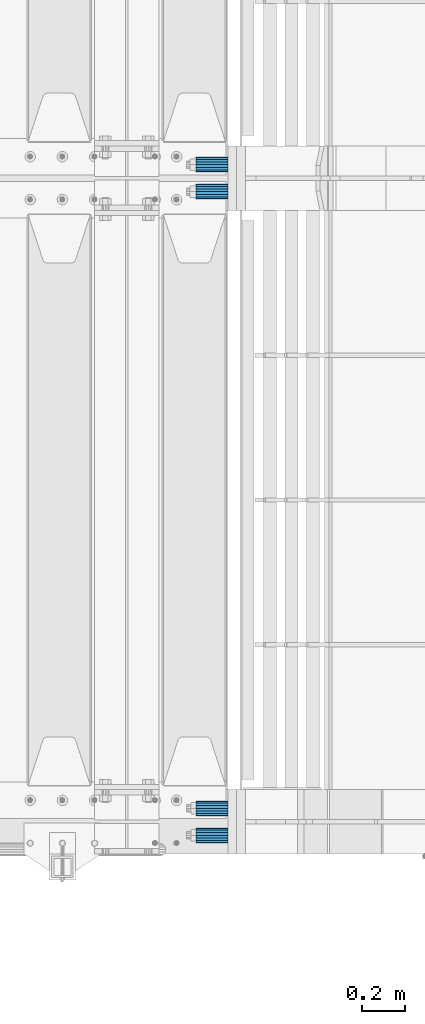
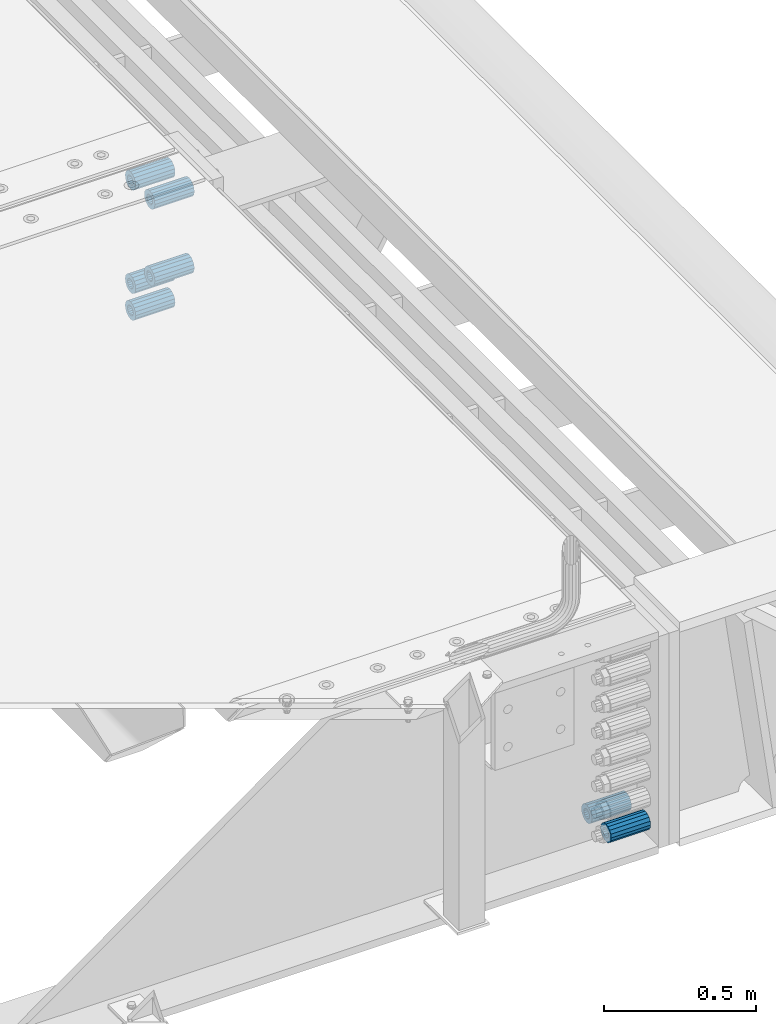
# One storey, part 162 of 257: 7 beams.
"""IFC2X3 building model written with IfcOpenShell, lengths in millimetres."""

from ifc_helpers import new_model, si_unit, frame, origin_with_axes, place, context, subcontext, project, spatial, faceted_brep, material, type_object, element, save


model = new_model("IFC2X3")

# Units and contexts
model_context = context("Model", 3, precision=1e-05, world=origin_with_axes())
body_context = subcontext(model_context, "Body", "Model", "MODEL_VIEW")
ifc_project = project(units=[si_unit("LENGTHUNIT", "METRE", prefix="MILLI"), si_unit("AREAUNIT", "SQUARE_METRE"), si_unit("VOLUMEUNIT", "CUBIC_METRE"), si_unit("MASSUNIT", "GRAM", prefix="KILO"), si_unit("TIMEUNIT", "SECOND"), si_unit("PLANEANGLEUNIT", "RADIAN"), si_unit("SOLIDANGLEUNIT", "STERADIAN"), si_unit("THERMODYNAMICTEMPERATUREUNIT", "DEGREE_CELSIUS"), si_unit("LUMINOUSINTENSITYUNIT", "LUMEN")], contexts=[model_context])

# Site, building, storey
site_placement = place(None, origin_with_axes())
site = spatial("IfcSite", under=ifc_project, at=site_placement, CompositionType="ELEMENT")
building_placement = place(site_placement, origin_with_axes())
building = spatial("IfcBuilding", under=site, at=building_placement, Name="Standard", CompositionType="ELEMENT")
storey_placement = place(building_placement, origin_with_axes())
storey = spatial("IfcBuildingStorey", under=building, at=storey_placement, Name="Undefined", CompositionType="ELEMENT", Elevation=0.0)

# Beams
ifc_material = material()
beam_type = type_object("IfcBeamType", PredefinedType="NOTDEFINED")
beam_1_placement = place(storey_placement, frame((59117.0, 3063.0, -84.0000000000001), z_axis=(0.0, 0.0, 1.0), x_axis=(1.0, 0.0, 0.0)))
element("IfcBeam", 1, at=beam_1_placement, inside=storey, type_object=beam_type, material=ifc_material, context=body_context, shape_type="Brep", body=[
    faceted_brep([(-1.3120632047503e-07, -18.9999999995493, -6.27187546342611e-09), (0.0, -17.5537111177146, 7.27098521493672), (150.0, -17.5537111177146, 7.27098521493672), (150.0, -19.0, 0.0), (0.0, -13.4350288425449, 13.4350288425444), (150.0, -13.4350288425449, 13.4350288425444), (0.0, -7.27098521493645, 17.5537111177144), (150.0, -7.27098521493645, 17.5537111177144), (-6.33792751614237e-09, 4.50654624728486e-10, 18.9999999937208), (150.0, 0.0, 19.0), (0.0, 7.27098521493645, 17.5537111177144), (150.0, 7.27098521493645, 17.5537111177144), (0.0, 13.4350288425449, 13.4350288425444), (150.0, 13.4350288425449, 13.4350288425444), (0.0, 17.5537111177146, 7.2709852149367), (150.0, 17.5537111177146, 7.2709852149367), (1.33208345687308e-07, 19.0000000004507, -6.27187546342611e-09), (150.0, 19.0, 0.0), (0.0, 17.5537111177146, -7.2709852149367), (150.0, 17.5537111177146, -7.2709852149367), (0.0, 13.4350288425449, -13.4350288425444), (150.0, 13.4350288425449, -13.4350288425444), (0.0, 7.27098521493645, -17.5537111177144), (150.0, 7.27098521493645, -17.5537111177144), (8.33983904158231e-09, 4.50654624728486e-10, -19.0000000062719), (150.0, 0.0, -19.0), (0.0, -7.27098521493645, -17.5537111177144), (150.0, -7.27098521493645, -17.5537111177144), (0.0, -13.4350288425449, -13.4350288425444), (150.0, -13.4350288425449, -13.4350288425444), (0.0, -17.5537111177146, -7.2709852149367), (150.0, -17.5537111177146, -7.2709852149367), (7.27595761418343e-12, -35.0, 0.0), (1.45519152283669e-11, -32.335783637895, -13.3939201327781), (150.0, -32.3357836378955, -13.3939201327782), (150.0, -35.0, 0.0), (7.27595761418343e-12, -24.7487373415292, -24.748737341529), (150.0, -24.7487373415288, -24.7487373415292), (7.27595761418343e-12, -13.3939201327781, -32.335783637895), (150.0, -13.3939201327785, -32.335783637895), (7.27595761418343e-12, 0.0, -35.0), (150.0, 0.0, -35.0), (7.27595761418343e-12, 13.3939201327782, -32.335783637895), (150.0, 13.3939201327785, -32.335783637895), (7.27595761418343e-12, 24.7487373415292, -24.748737341529), (150.0, 24.7487373415288, -24.7487373415292), (1.45519152283669e-11, 32.335783637895, -13.3939201327781), (150.0, 32.3357836378955, -13.3939201327781), (7.27595761418343e-12, 35.0, 0.0), (150.0, 35.0, 0.0), (7.27595761418343e-12, 32.335783637895, 13.3939201327782), (150.0, 32.3357836378955, 13.3939201327781), (7.27595761418343e-12, 24.7487373415292, 24.7487373415291), (150.0, 24.7487373415288, 24.7487373415292), (1.45519152283669e-11, 13.3939201327781, 32.335783637895), (150.0, 13.3939201327785, 32.335783637895), (1.45519152283669e-11, 0.0, 35.0000000000001), (150.0, 0.0, 35.0), (1.45519152283669e-11, -13.3939201327781, 32.335783637895), (150.0, -13.3939201327785, 32.335783637895), (7.27595761418343e-12, -24.7487373415292, 24.7487373415291), (150.0, -24.7487373415288, 24.7487373415292), (7.27595761418343e-12, -32.335783637895, 13.3939201327782), (150.0, -32.3357836378955, 13.3939201327781)], [[[0, 1, 2, 3]], [[1, 4, 5, 2]], [[4, 6, 7, 5]], [[6, 8, 9, 7]], [[8, 10, 11, 9]], [[10, 12, 13, 11]], [[12, 14, 15, 13]], [[14, 16, 17, 15]], [[16, 18, 19, 17]], [[18, 20, 21, 19]], [[20, 22, 23, 21]], [[22, 24, 25, 23]], [[24, 26, 27, 25]], [[26, 28, 29, 27]], [[28, 30, 31, 29]], [[30, 0, 3, 31]], [[32, 33, 34, 35]], [[33, 36, 37, 34]], [[36, 38, 39, 37]], [[38, 40, 41, 39]], [[40, 42, 43, 41]], [[42, 44, 45, 43]], [[44, 46, 47, 45]], [[46, 48, 49, 47]], [[48, 50, 51, 49]], [[50, 52, 53, 51]], [[52, 54, 55, 53]], [[54, 56, 57, 55]], [[56, 58, 59, 57]], [[58, 60, 61, 59]], [[60, 62, 63, 61]], [[62, 32, 35, 63]], [[37, 39, 41, 43, 45, 47, 49, 51, 53, 55, 57, 59, 61, 63, 35, 34], [5, 7, 9, 11, 13, 15, 17, 19, 21, 23, 25, 27, 29, 31, 3, 2]], [[62, 60, 58, 56, 54, 52, 50, 48, 46, 44, 42, 40, 38, 36, 33, 32], [30, 28, 26, 24, 22, 20, 18, 16, 14, 12, 10, 8, 6, 4, 1, 0]]]),
])
beam_2_placement = place(storey_placement, frame((59117.0, 2937.0, -84.0000000000001), z_axis=(0.0, 0.0, 1.0), x_axis=(1.0, 0.0, 0.0)))
element("IfcBeam", 2, at=beam_2_placement, inside=storey, type_object=beam_type, material=ifc_material, context=body_context, shape_type="Brep", body=[
    faceted_brep([(-1.3120632047503e-07, -18.9999999995493, -6.27187546342611e-09), (0.0, -17.5537111177146, 7.27098521493672), (150.0, -17.5537111177146, 7.27098521493672), (150.0, -19.0, 0.0), (0.0, -13.4350288425449, 13.4350288425444), (150.0, -13.4350288425449, 13.4350288425444), (0.0, -7.27098521493645, 17.5537111177144), (150.0, -7.27098521493645, 17.5537111177144), (-6.33792751614237e-09, 4.50654624728486e-10, 18.9999999937208), (150.0, 0.0, 19.0), (0.0, 7.27098521493645, 17.5537111177144), (150.0, 7.27098521493645, 17.5537111177144), (0.0, 13.4350288425449, 13.4350288425444), (150.0, 13.4350288425449, 13.4350288425444), (0.0, 17.5537111177146, 7.2709852149367), (150.0, 17.5537111177146, 7.2709852149367), (1.33208345687308e-07, 19.0000000004507, -6.27187546342611e-09), (150.0, 19.0, 0.0), (0.0, 17.5537111177146, -7.2709852149367), (150.0, 17.5537111177146, -7.2709852149367), (0.0, 13.4350288425449, -13.4350288425444), (150.0, 13.4350288425449, -13.4350288425444), (0.0, 7.27098521493645, -17.5537111177144), (150.0, 7.27098521493645, -17.5537111177144), (8.33983904158231e-09, 4.50654624728486e-10, -19.0000000062719), (150.0, 0.0, -19.0), (0.0, -7.27098521493645, -17.5537111177144), (150.0, -7.27098521493645, -17.5537111177144), (0.0, -13.4350288425449, -13.4350288425444), (150.0, -13.4350288425449, -13.4350288425444), (0.0, -17.5537111177146, -7.2709852149367), (150.0, -17.5537111177146, -7.2709852149367), (7.27595761418343e-12, -35.0, 0.0), (1.45519152283669e-11, -32.335783637895, -13.3939201327781), (150.0, -32.3357836378955, -13.3939201327782), (150.0, -35.0, 0.0), (7.27595761418343e-12, -24.7487373415292, -24.748737341529), (150.0, -24.7487373415288, -24.7487373415292), (7.27595761418343e-12, -13.3939201327781, -32.335783637895), (150.0, -13.3939201327785, -32.335783637895), (7.27595761418343e-12, 0.0, -35.0), (150.0, 0.0, -35.0), (7.27595761418343e-12, 13.3939201327782, -32.335783637895), (150.0, 13.3939201327785, -32.335783637895), (7.27595761418343e-12, 24.7487373415292, -24.748737341529), (150.0, 24.7487373415288, -24.7487373415292), (1.45519152283669e-11, 32.335783637895, -13.3939201327781), (150.0, 32.3357836378955, -13.3939201327781), (7.27595761418343e-12, 35.0, 0.0), (150.0, 35.0, 0.0), (7.27595761418343e-12, 32.335783637895, 13.3939201327782), (150.0, 32.3357836378955, 13.3939201327781), (7.27595761418343e-12, 24.7487373415292, 24.7487373415291), (150.0, 24.7487373415288, 24.7487373415292), (1.45519152283669e-11, 13.3939201327781, 32.335783637895), (150.0, 13.3939201327785, 32.335783637895), (1.45519152283669e-11, 0.0, 35.0000000000001), (150.0, 0.0, 35.0), (1.45519152283669e-11, -13.3939201327781, 32.335783637895), (150.0, -13.3939201327785, 32.335783637895), (7.27595761418343e-12, -24.7487373415292, 24.7487373415291), (150.0, -24.7487373415288, 24.7487373415292), (7.27595761418343e-12, -32.335783637895, 13.3939201327782), (150.0, -32.3357836378955, 13.3939201327781)], [[[0, 1, 2, 3]], [[1, 4, 5, 2]], [[4, 6, 7, 5]], [[6, 8, 9, 7]], [[8, 10, 11, 9]], [[10, 12, 13, 11]], [[12, 14, 15, 13]], [[14, 16, 17, 15]], [[16, 18, 19, 17]], [[18, 20, 21, 19]], [[20, 22, 23, 21]], [[22, 24, 25, 23]], [[24, 26, 27, 25]], [[26, 28, 29, 27]], [[28, 30, 31, 29]], [[30, 0, 3, 31]], [[32, 33, 34, 35]], [[33, 36, 37, 34]], [[36, 38, 39, 37]], [[38, 40, 41, 39]], [[40, 42, 43, 41]], [[42, 44, 45, 43]], [[44, 46, 47, 45]], [[46, 48, 49, 47]], [[48, 50, 51, 49]], [[50, 52, 53, 51]], [[52, 54, 55, 53]], [[54, 56, 57, 55]], [[56, 58, 59, 57]], [[58, 60, 61, 59]], [[60, 62, 63, 61]], [[62, 32, 35, 63]], [[37, 39, 41, 43, 45, 47, 49, 51, 53, 55, 57, 59, 61, 63, 35, 34], [5, 7, 9, 11, 13, 15, 17, 19, 21, 23, 25, 27, 29, 31, 3, 2]], [[62, 60, 58, 56, 54, 52, 50, 48, 46, 44, 42, 40, 38, 36, 33, 32], [30, 28, 26, 24, 22, 20, 18, 16, 14, 12, 10, 8, 6, 4, 1, 0]]]),
])
beam_3_placement = place(storey_placement, frame((59117.0, 2937.0, -392.0), z_axis=(0.0, 0.0, 1.0), x_axis=(1.0, 0.0, 0.0)))
element("IfcBeam", 3, at=beam_3_placement, inside=storey, type_object=beam_type, material=ifc_material, context=body_context, shape_type="Brep", body=[
    faceted_brep([(-1.3120632047503e-07, -18.9999999995493, -6.27187546342611e-09), (0.0, -17.5537111177146, 7.27098521493672), (150.0, -17.5537111177146, 7.27098521493672), (150.0, -19.0, 0.0), (0.0, -13.4350288425449, 13.4350288425444), (150.0, -13.4350288425449, 13.4350288425444), (0.0, -7.27098521493645, 17.5537111177144), (150.0, -7.27098521493645, 17.5537111177144), (-6.33792751614237e-09, 4.50654624728486e-10, 18.9999999937208), (150.0, 0.0, 19.0), (0.0, 7.27098521493645, 17.5537111177144), (150.0, 7.27098521493645, 17.5537111177144), (0.0, 13.4350288425449, 13.4350288425444), (150.0, 13.4350288425449, 13.4350288425444), (0.0, 17.5537111177146, 7.2709852149367), (150.0, 17.5537111177146, 7.2709852149367), (1.33208345687308e-07, 19.0000000004507, -6.27187546342611e-09), (150.0, 19.0, 0.0), (0.0, 17.5537111177146, -7.2709852149367), (150.0, 17.5537111177146, -7.2709852149367), (0.0, 13.4350288425449, -13.4350288425444), (150.0, 13.4350288425449, -13.4350288425444), (0.0, 7.27098521493645, -17.5537111177144), (150.0, 7.27098521493645, -17.5537111177144), (8.33983904158231e-09, 4.50654624728486e-10, -19.0000000062719), (150.0, 0.0, -19.0), (0.0, -7.27098521493645, -17.5537111177144), (150.0, -7.27098521493645, -17.5537111177144), (0.0, -13.4350288425449, -13.4350288425444), (150.0, -13.4350288425449, -13.4350288425444), (0.0, -17.5537111177146, -7.2709852149367), (150.0, -17.5537111177146, -7.2709852149367), (7.27595761418343e-12, -35.0, 0.0), (1.45519152283669e-11, -32.335783637895, -13.3939201327781), (150.0, -32.3357836378955, -13.3939201327782), (150.0, -35.0, 0.0), (7.27595761418343e-12, -24.7487373415292, -24.748737341529), (150.0, -24.7487373415288, -24.7487373415292), (7.27595761418343e-12, -13.3939201327781, -32.335783637895), (150.0, -13.3939201327785, -32.335783637895), (7.27595761418343e-12, 0.0, -35.0), (150.0, 0.0, -35.0), (7.27595761418343e-12, 13.3939201327782, -32.335783637895), (150.0, 13.3939201327785, -32.335783637895), (7.27595761418343e-12, 24.7487373415292, -24.748737341529), (150.0, 24.7487373415288, -24.7487373415292), (1.45519152283669e-11, 32.335783637895, -13.3939201327781), (150.0, 32.3357836378955, -13.3939201327781), (7.27595761418343e-12, 35.0, 0.0), (150.0, 35.0, 0.0), (7.27595761418343e-12, 32.335783637895, 13.3939201327782), (150.0, 32.3357836378955, 13.3939201327781), (7.27595761418343e-12, 24.7487373415292, 24.7487373415291), (150.0, 24.7487373415288, 24.7487373415292), (1.45519152283669e-11, 13.3939201327781, 32.335783637895), (150.0, 13.3939201327785, 32.335783637895), (1.45519152283669e-11, 0.0, 35.0000000000001), (150.0, 0.0, 35.0), (1.45519152283669e-11, -13.3939201327781, 32.335783637895), (150.0, -13.3939201327785, 32.335783637895), (7.27595761418343e-12, -24.7487373415292, 24.7487373415291), (150.0, -24.7487373415288, 24.7487373415292), (7.27595761418343e-12, -32.335783637895, 13.3939201327782), (150.0, -32.3357836378955, 13.3939201327781)], [[[0, 1, 2, 3]], [[1, 4, 5, 2]], [[4, 6, 7, 5]], [[6, 8, 9, 7]], [[8, 10, 11, 9]], [[10, 12, 13, 11]], [[12, 14, 15, 13]], [[14, 16, 17, 15]], [[16, 18, 19, 17]], [[18, 20, 21, 19]], [[20, 22, 23, 21]], [[22, 24, 25, 23]], [[24, 26, 27, 25]], [[26, 28, 29, 27]], [[28, 30, 31, 29]], [[30, 0, 3, 31]], [[32, 33, 34, 35]], [[33, 36, 37, 34]], [[36, 38, 39, 37]], [[38, 40, 41, 39]], [[40, 42, 43, 41]], [[42, 44, 45, 43]], [[44, 46, 47, 45]], [[46, 48, 49, 47]], [[48, 50, 51, 49]], [[50, 52, 53, 51]], [[52, 54, 55, 53]], [[54, 56, 57, 55]], [[56, 58, 59, 57]], [[58, 60, 61, 59]], [[60, 62, 63, 61]], [[62, 32, 35, 63]], [[37, 39, 41, 43, 45, 47, 49, 51, 53, 55, 57, 59, 61, 63, 35, 34], [5, 7, 9, 11, 13, 15, 17, 19, 21, 23, 25, 27, 29, 31, 3, 2]], [[62, 60, 58, 56, 54, 52, 50, 48, 46, 44, 42, 40, 38, 36, 33, 32], [30, 28, 26, 24, 22, 20, 18, 16, 14, 12, 10, 8, 6, 4, 1, 0]]]),
])
beam_4_placement = place(storey_placement, frame((59117.0, 3063.0, -606.0), z_axis=(0.0, 0.0, 1.0), x_axis=(1.0, 0.0, 0.0)))
element("IfcBeam", 4, at=beam_4_placement, inside=storey, type_object=beam_type, material=ifc_material, context=body_context, shape_type="Brep", body=[
    faceted_brep([(-1.3120632047503e-07, -18.9999999995493, -6.27187546342611e-09), (0.0, -17.5537111177146, 7.27098521493672), (150.0, -17.5537111177146, 7.27098521493672), (150.0, -19.0, 0.0), (0.0, -13.4350288425449, 13.4350288425444), (150.0, -13.4350288425449, 13.4350288425444), (0.0, -7.27098521493645, 17.5537111177144), (150.0, -7.27098521493645, 17.5537111177144), (-6.33792751614237e-09, 4.50654624728486e-10, 18.9999999937208), (150.0, 0.0, 19.0), (0.0, 7.27098521493645, 17.5537111177144), (150.0, 7.27098521493645, 17.5537111177144), (0.0, 13.4350288425449, 13.4350288425444), (150.0, 13.4350288425449, 13.4350288425444), (0.0, 17.5537111177146, 7.2709852149367), (150.0, 17.5537111177146, 7.2709852149367), (1.33208345687308e-07, 19.0000000004507, -6.27187546342611e-09), (150.0, 19.0, 0.0), (0.0, 17.5537111177146, -7.2709852149367), (150.0, 17.5537111177146, -7.2709852149367), (0.0, 13.4350288425449, -13.4350288425444), (150.0, 13.4350288425449, -13.4350288425444), (0.0, 7.27098521493645, -17.5537111177144), (150.0, 7.27098521493645, -17.5537111177144), (8.33983904158231e-09, 4.50654624728486e-10, -19.0000000062719), (150.0, 0.0, -19.0), (0.0, -7.27098521493645, -17.5537111177144), (150.0, -7.27098521493645, -17.5537111177144), (0.0, -13.4350288425449, -13.4350288425444), (150.0, -13.4350288425449, -13.4350288425444), (0.0, -17.5537111177146, -7.2709852149367), (150.0, -17.5537111177146, -7.2709852149367), (7.27595761418343e-12, -35.0, 0.0), (1.45519152283669e-11, -32.335783637895, -13.3939201327781), (150.0, -32.3357836378955, -13.3939201327782), (150.0, -35.0, 0.0), (7.27595761418343e-12, -24.7487373415292, -24.748737341529), (150.0, -24.7487373415288, -24.7487373415292), (7.27595761418343e-12, -13.3939201327781, -32.335783637895), (150.0, -13.3939201327785, -32.335783637895), (7.27595761418343e-12, 0.0, -35.0), (150.0, 0.0, -35.0), (7.27595761418343e-12, 13.3939201327782, -32.335783637895), (150.0, 13.3939201327785, -32.335783637895), (7.27595761418343e-12, 24.7487373415292, -24.748737341529), (150.0, 24.7487373415288, -24.7487373415292), (1.45519152283669e-11, 32.335783637895, -13.3939201327781), (150.0, 32.3357836378955, -13.3939201327781), (7.27595761418343e-12, 35.0, 0.0), (150.0, 35.0, 0.0), (7.27595761418343e-12, 32.335783637895, 13.3939201327782), (150.0, 32.3357836378955, 13.3939201327781), (7.27595761418343e-12, 24.7487373415292, 24.7487373415291), (150.0, 24.7487373415288, 24.7487373415292), (1.45519152283669e-11, 13.3939201327781, 32.335783637895), (150.0, 13.3939201327785, 32.335783637895), (1.45519152283669e-11, 0.0, 35.0000000000001), (150.0, 0.0, 35.0), (1.45519152283669e-11, -13.3939201327781, 32.335783637895), (150.0, -13.3939201327785, 32.335783637895), (7.27595761418343e-12, -24.7487373415292, 24.7487373415291), (150.0, -24.7487373415288, 24.7487373415292), (7.27595761418343e-12, -32.335783637895, 13.3939201327782), (150.0, -32.3357836378955, 13.3939201327781)], [[[0, 1, 2, 3]], [[1, 4, 5, 2]], [[4, 6, 7, 5]], [[6, 8, 9, 7]], [[8, 10, 11, 9]], [[10, 12, 13, 11]], [[12, 14, 15, 13]], [[14, 16, 17, 15]], [[16, 18, 19, 17]], [[18, 20, 21, 19]], [[20, 22, 23, 21]], [[22, 24, 25, 23]], [[24, 26, 27, 25]], [[26, 28, 29, 27]], [[28, 30, 31, 29]], [[30, 0, 3, 31]], [[32, 33, 34, 35]], [[33, 36, 37, 34]], [[36, 38, 39, 37]], [[38, 40, 41, 39]], [[40, 42, 43, 41]], [[42, 44, 45, 43]], [[44, 46, 47, 45]], [[46, 48, 49, 47]], [[48, 50, 51, 49]], [[50, 52, 53, 51]], [[52, 54, 55, 53]], [[54, 56, 57, 55]], [[56, 58, 59, 57]], [[58, 60, 61, 59]], [[60, 62, 63, 61]], [[62, 32, 35, 63]], [[37, 39, 41, 43, 45, 47, 49, 51, 53, 55, 57, 59, 61, 63, 35, 34], [5, 7, 9, 11, 13, 15, 17, 19, 21, 23, 25, 27, 29, 31, 3, 2]], [[62, 60, 58, 56, 54, 52, 50, 48, 46, 44, 42, 40, 38, 36, 33, 32], [30, 28, 26, 24, 22, 20, 18, 16, 14, 12, 10, 8, 6, 4, 1, 0]]]),
])
beam_5_placement = place(storey_placement, frame((59117.0, 3063.0, -499.0), z_axis=(0.0, 0.0, 1.0), x_axis=(1.0, 0.0, 0.0)))
element("IfcBeam", 5, at=beam_5_placement, inside=storey, type_object=beam_type, material=ifc_material, context=body_context, shape_type="Brep", body=[
    faceted_brep([(-1.3120632047503e-07, -18.9999999995493, -6.27187546342611e-09), (0.0, -17.5537111177146, 7.27098521493672), (150.0, -17.5537111177146, 7.27098521493672), (150.0, -19.0, 0.0), (0.0, -13.4350288425449, 13.4350288425444), (150.0, -13.4350288425449, 13.4350288425444), (0.0, -7.27098521493645, 17.5537111177144), (150.0, -7.27098521493645, 17.5537111177144), (-6.33792751614237e-09, 4.50654624728486e-10, 18.9999999937208), (150.0, 0.0, 19.0), (0.0, 7.27098521493645, 17.5537111177144), (150.0, 7.27098521493645, 17.5537111177144), (0.0, 13.4350288425449, 13.4350288425444), (150.0, 13.4350288425449, 13.4350288425444), (0.0, 17.5537111177146, 7.2709852149367), (150.0, 17.5537111177146, 7.2709852149367), (1.33208345687308e-07, 19.0000000004507, -6.27187546342611e-09), (150.0, 19.0, 0.0), (0.0, 17.5537111177146, -7.2709852149367), (150.0, 17.5537111177146, -7.2709852149367), (0.0, 13.4350288425449, -13.4350288425444), (150.0, 13.4350288425449, -13.4350288425444), (0.0, 7.27098521493645, -17.5537111177144), (150.0, 7.27098521493645, -17.5537111177144), (8.33983904158231e-09, 4.50654624728486e-10, -19.0000000062719), (150.0, 0.0, -19.0), (0.0, -7.27098521493645, -17.5537111177144), (150.0, -7.27098521493645, -17.5537111177144), (0.0, -13.4350288425449, -13.4350288425444), (150.0, -13.4350288425449, -13.4350288425444), (0.0, -17.5537111177146, -7.2709852149367), (150.0, -17.5537111177146, -7.2709852149367), (7.27595761418343e-12, -35.0, 0.0), (1.45519152283669e-11, -32.335783637895, -13.3939201327781), (150.0, -32.3357836378955, -13.3939201327782), (150.0, -35.0, 0.0), (7.27595761418343e-12, -24.7487373415292, -24.748737341529), (150.0, -24.7487373415288, -24.7487373415292), (7.27595761418343e-12, -13.3939201327781, -32.335783637895), (150.0, -13.3939201327785, -32.335783637895), (7.27595761418343e-12, 0.0, -35.0), (150.0, 0.0, -35.0), (7.27595761418343e-12, 13.3939201327782, -32.335783637895), (150.0, 13.3939201327785, -32.335783637895), (7.27595761418343e-12, 24.7487373415292, -24.748737341529), (150.0, 24.7487373415288, -24.7487373415292), (1.45519152283669e-11, 32.335783637895, -13.3939201327781), (150.0, 32.3357836378955, -13.3939201327781), (7.27595761418343e-12, 35.0, 0.0), (150.0, 35.0, 0.0), (7.27595761418343e-12, 32.335783637895, 13.3939201327782), (150.0, 32.3357836378955, 13.3939201327781), (7.27595761418343e-12, 24.7487373415292, 24.7487373415291), (150.0, 24.7487373415288, 24.7487373415292), (1.45519152283669e-11, 13.3939201327781, 32.335783637895), (150.0, 13.3939201327785, 32.335783637895), (1.45519152283669e-11, 0.0, 35.0000000000001), (150.0, 0.0, 35.0), (1.45519152283669e-11, -13.3939201327781, 32.335783637895), (150.0, -13.3939201327785, 32.335783637895), (7.27595761418343e-12, -24.7487373415292, 24.7487373415291), (150.0, -24.7487373415288, 24.7487373415292), (7.27595761418343e-12, -32.335783637895, 13.3939201327782), (150.0, -32.3357836378955, 13.3939201327781)], [[[0, 1, 2, 3]], [[1, 4, 5, 2]], [[4, 6, 7, 5]], [[6, 8, 9, 7]], [[8, 10, 11, 9]], [[10, 12, 13, 11]], [[12, 14, 15, 13]], [[14, 16, 17, 15]], [[16, 18, 19, 17]], [[18, 20, 21, 19]], [[20, 22, 23, 21]], [[22, 24, 25, 23]], [[24, 26, 27, 25]], [[26, 28, 29, 27]], [[28, 30, 31, 29]], [[30, 0, 3, 31]], [[32, 33, 34, 35]], [[33, 36, 37, 34]], [[36, 38, 39, 37]], [[38, 40, 41, 39]], [[40, 42, 43, 41]], [[42, 44, 45, 43]], [[44, 46, 47, 45]], [[46, 48, 49, 47]], [[48, 50, 51, 49]], [[50, 52, 53, 51]], [[52, 54, 55, 53]], [[54, 56, 57, 55]], [[56, 58, 59, 57]], [[58, 60, 61, 59]], [[60, 62, 63, 61]], [[62, 32, 35, 63]], [[37, 39, 41, 43, 45, 47, 49, 51, 53, 55, 57, 59, 61, 63, 35, 34], [5, 7, 9, 11, 13, 15, 17, 19, 21, 23, 25, 27, 29, 31, 3, 2]], [[62, 60, 58, 56, 54, 52, 50, 48, 46, 44, 42, 40, 38, 36, 33, 32], [30, 28, 26, 24, 22, 20, 18, 16, 14, 12, 10, 8, 6, 4, 1, 0]]]),
])
beam_6_placement = place(storey_placement, frame((59117.0, 63.0, -807.0), z_axis=(0.0, 0.0, 1.0), x_axis=(1.0, 0.0, 0.0)))
element("IfcBeam", 6, at=beam_6_placement, inside=storey, type_object=beam_type, material=ifc_material, context=body_context, shape_type="Brep", body=[
    faceted_brep([(-1.3120632047503e-07, -18.9999999995493, -6.27187546342611e-09), (0.0, -17.5537111177146, 7.27098521493672), (150.0, -17.5537111177146, 7.27098521493672), (150.0, -19.0, 0.0), (0.0, -13.4350288425449, 13.4350288425444), (150.0, -13.4350288425449, 13.4350288425444), (0.0, -7.27098521493645, 17.5537111177144), (150.0, -7.27098521493645, 17.5537111177144), (-6.33792751614237e-09, 4.50654624728486e-10, 18.9999999937208), (150.0, 0.0, 19.0), (0.0, 7.27098521493645, 17.5537111177144), (150.0, 7.27098521493645, 17.5537111177144), (0.0, 13.4350288425449, 13.4350288425444), (150.0, 13.4350288425449, 13.4350288425444), (0.0, 17.5537111177146, 7.2709852149367), (150.0, 17.5537111177146, 7.2709852149367), (1.33208345687308e-07, 19.0000000004507, -6.27187546342611e-09), (150.0, 19.0, 0.0), (0.0, 17.5537111177146, -7.2709852149367), (150.0, 17.5537111177146, -7.2709852149367), (0.0, 13.4350288425449, -13.4350288425444), (150.0, 13.4350288425449, -13.4350288425444), (0.0, 7.27098521493645, -17.5537111177144), (150.0, 7.27098521493645, -17.5537111177144), (8.33983904158231e-09, 4.50654624728486e-10, -19.0000000062719), (150.0, 0.0, -19.0), (0.0, -7.27098521493645, -17.5537111177144), (150.0, -7.27098521493645, -17.5537111177144), (0.0, -13.4350288425449, -13.4350288425444), (150.0, -13.4350288425449, -13.4350288425444), (0.0, -17.5537111177146, -7.2709852149367), (150.0, -17.5537111177146, -7.2709852149367), (7.27595761418343e-12, -35.0, 0.0), (1.45519152283669e-11, -32.335783637895, -13.3939201327781), (150.0, -32.3357836378955, -13.3939201327782), (150.0, -35.0, 0.0), (7.27595761418343e-12, -24.7487373415292, -24.748737341529), (150.0, -24.7487373415288, -24.7487373415292), (7.27595761418343e-12, -13.3939201327781, -32.335783637895), (150.0, -13.3939201327785, -32.335783637895), (7.27595761418343e-12, 0.0, -35.0), (150.0, 0.0, -35.0), (7.27595761418343e-12, 13.3939201327782, -32.335783637895), (150.0, 13.3939201327785, -32.335783637895), (7.27595761418343e-12, 24.7487373415292, -24.748737341529), (150.0, 24.7487373415288, -24.7487373415292), (1.45519152283669e-11, 32.335783637895, -13.3939201327781), (150.0, 32.3357836378955, -13.3939201327781), (7.27595761418343e-12, 35.0, 0.0), (150.0, 35.0, 0.0), (7.27595761418343e-12, 32.335783637895, 13.3939201327782), (150.0, 32.3357836378955, 13.3939201327781), (7.27595761418343e-12, 24.7487373415292, 24.7487373415291), (150.0, 24.7487373415288, 24.7487373415292), (1.45519152283669e-11, 13.3939201327781, 32.335783637895), (150.0, 13.3939201327785, 32.335783637895), (1.45519152283669e-11, 0.0, 35.0000000000001), (150.0, 0.0, 35.0), (1.45519152283669e-11, -13.3939201327781, 32.335783637895), (150.0, -13.3939201327785, 32.335783637895), (7.27595761418343e-12, -24.7487373415292, 24.7487373415291), (150.0, -24.7487373415288, 24.7487373415292), (7.27595761418343e-12, -32.335783637895, 13.3939201327782), (150.0, -32.3357836378955, 13.3939201327781)], [[[0, 1, 2, 3]], [[1, 4, 5, 2]], [[4, 6, 7, 5]], [[6, 8, 9, 7]], [[8, 10, 11, 9]], [[10, 12, 13, 11]], [[12, 14, 15, 13]], [[14, 16, 17, 15]], [[16, 18, 19, 17]], [[18, 20, 21, 19]], [[20, 22, 23, 21]], [[22, 24, 25, 23]], [[24, 26, 27, 25]], [[26, 28, 29, 27]], [[28, 30, 31, 29]], [[30, 0, 3, 31]], [[32, 33, 34, 35]], [[33, 36, 37, 34]], [[36, 38, 39, 37]], [[38, 40, 41, 39]], [[40, 42, 43, 41]], [[42, 44, 45, 43]], [[44, 46, 47, 45]], [[46, 48, 49, 47]], [[48, 50, 51, 49]], [[50, 52, 53, 51]], [[52, 54, 55, 53]], [[54, 56, 57, 55]], [[56, 58, 59, 57]], [[58, 60, 61, 59]], [[60, 62, 63, 61]], [[62, 32, 35, 63]], [[37, 39, 41, 43, 45, 47, 49, 51, 53, 55, 57, 59, 61, 63, 35, 34], [5, 7, 9, 11, 13, 15, 17, 19, 21, 23, 25, 27, 29, 31, 3, 2]], [[62, 60, 58, 56, 54, 52, 50, 48, 46, 44, 42, 40, 38, 36, 33, 32], [30, 28, 26, 24, 22, 20, 18, 16, 14, 12, 10, 8, 6, 4, 1, 0]]]),
])
beam_7_placement = place(storey_placement, frame((59117.0, -63.0, -807.0), z_axis=(0.0, 0.0, 1.0), x_axis=(1.0, 0.0, 0.0)))
element("IfcBeam", 7, at=beam_7_placement, inside=storey, type_object=beam_type, material=ifc_material, context=body_context, shape_type="Brep", body=[
    faceted_brep([(-1.3120632047503e-07, -18.9999999995493, -6.27187546342611e-09), (0.0, -17.5537111177146, 7.27098521493672), (150.0, -17.5537111177146, 7.27098521493672), (150.0, -19.0, 0.0), (0.0, -13.4350288425449, 13.4350288425444), (150.0, -13.4350288425449, 13.4350288425444), (0.0, -7.27098521493645, 17.5537111177144), (150.0, -7.27098521493645, 17.5537111177144), (-6.33792751614237e-09, 4.50654624728486e-10, 18.9999999937208), (150.0, 0.0, 19.0), (0.0, 7.27098521493645, 17.5537111177144), (150.0, 7.27098521493645, 17.5537111177144), (0.0, 13.4350288425449, 13.4350288425444), (150.0, 13.4350288425449, 13.4350288425444), (0.0, 17.5537111177146, 7.2709852149367), (150.0, 17.5537111177146, 7.2709852149367), (1.33208345687308e-07, 19.0000000004507, -6.27187546342611e-09), (150.0, 19.0, 0.0), (0.0, 17.5537111177146, -7.2709852149367), (150.0, 17.5537111177146, -7.2709852149367), (0.0, 13.4350288425449, -13.4350288425444), (150.0, 13.4350288425449, -13.4350288425444), (0.0, 7.27098521493645, -17.5537111177144), (150.0, 7.27098521493645, -17.5537111177144), (8.33983904158231e-09, 4.50654624728486e-10, -19.0000000062719), (150.0, 0.0, -19.0), (0.0, -7.27098521493645, -17.5537111177144), (150.0, -7.27098521493645, -17.5537111177144), (0.0, -13.4350288425449, -13.4350288425444), (150.0, -13.4350288425449, -13.4350288425444), (0.0, -17.5537111177146, -7.2709852149367), (150.0, -17.5537111177146, -7.2709852149367), (7.27595761418343e-12, -35.0, 0.0), (1.45519152283669e-11, -32.335783637895, -13.3939201327781), (150.0, -32.3357836378955, -13.3939201327782), (150.0, -35.0, 0.0), (7.27595761418343e-12, -24.7487373415292, -24.748737341529), (150.0, -24.7487373415288, -24.7487373415292), (7.27595761418343e-12, -13.3939201327781, -32.335783637895), (150.0, -13.3939201327785, -32.335783637895), (7.27595761418343e-12, 0.0, -35.0), (150.0, 0.0, -35.0), (7.27595761418343e-12, 13.3939201327782, -32.335783637895), (150.0, 13.3939201327785, -32.335783637895), (7.27595761418343e-12, 24.7487373415292, -24.748737341529), (150.0, 24.7487373415288, -24.7487373415292), (1.45519152283669e-11, 32.335783637895, -13.3939201327781), (150.0, 32.3357836378955, -13.3939201327781), (7.27595761418343e-12, 35.0, 0.0), (150.0, 35.0, 0.0), (7.27595761418343e-12, 32.335783637895, 13.3939201327782), (150.0, 32.3357836378955, 13.3939201327781), (7.27595761418343e-12, 24.7487373415292, 24.7487373415291), (150.0, 24.7487373415288, 24.7487373415292), (1.45519152283669e-11, 13.3939201327781, 32.335783637895), (150.0, 13.3939201327785, 32.335783637895), (1.45519152283669e-11, 0.0, 35.0000000000001), (150.0, 0.0, 35.0), (1.45519152283669e-11, -13.3939201327781, 32.335783637895), (150.0, -13.3939201327785, 32.335783637895), (7.27595761418343e-12, -24.7487373415292, 24.7487373415291), (150.0, -24.7487373415288, 24.7487373415292), (7.27595761418343e-12, -32.335783637895, 13.3939201327782), (150.0, -32.3357836378955, 13.3939201327781)], [[[0, 1, 2, 3]], [[1, 4, 5, 2]], [[4, 6, 7, 5]], [[6, 8, 9, 7]], [[8, 10, 11, 9]], [[10, 12, 13, 11]], [[12, 14, 15, 13]], [[14, 16, 17, 15]], [[16, 18, 19, 17]], [[18, 20, 21, 19]], [[20, 22, 23, 21]], [[22, 24, 25, 23]], [[24, 26, 27, 25]], [[26, 28, 29, 27]], [[28, 30, 31, 29]], [[30, 0, 3, 31]], [[32, 33, 34, 35]], [[33, 36, 37, 34]], [[36, 38, 39, 37]], [[38, 40, 41, 39]], [[40, 42, 43, 41]], [[42, 44, 45, 43]], [[44, 46, 47, 45]], [[46, 48, 49, 47]], [[48, 50, 51, 49]], [[50, 52, 53, 51]], [[52, 54, 55, 53]], [[54, 56, 57, 55]], [[56, 58, 59, 57]], [[58, 60, 61, 59]], [[60, 62, 63, 61]], [[62, 32, 35, 63]], [[37, 39, 41, 43, 45, 47, 49, 51, 53, 55, 57, 59, 61, 63, 35, 34], [5, 7, 9, 11, 13, 15, 17, 19, 21, 23, 25, 27, 29, 31, 3, 2]], [[62, 60, 58, 56, 54, 52, 50, 48, 46, 44, 42, 40, 38, 36, 33, 32], [30, 28, 26, 24, 22, 20, 18, 16, 14, 12, 10, 8, 6, 4, 1, 0]]]),
])

save(model, "model.ifc")
